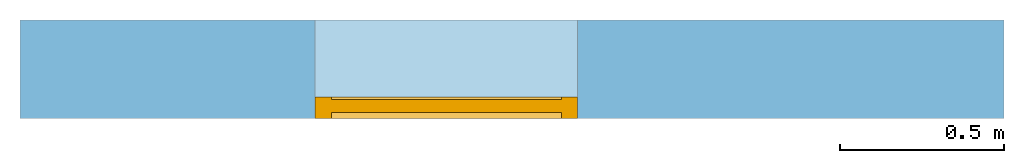
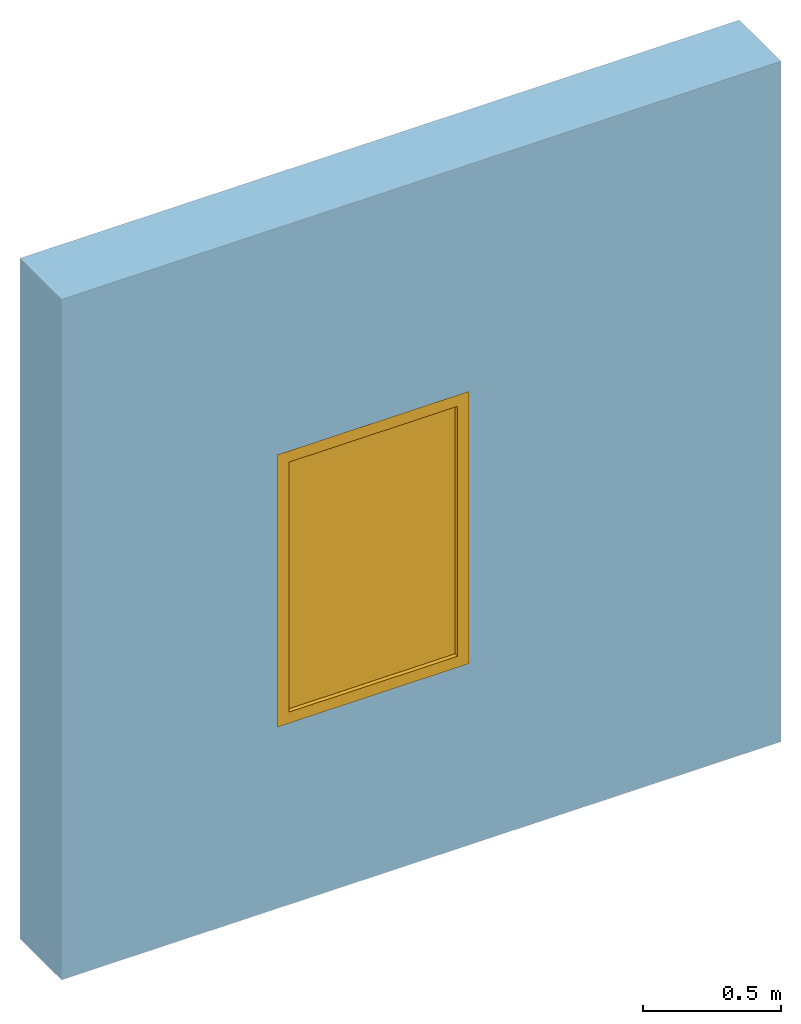
# One storey, part 2 of 2: 1 window, 1 opening, plus 1 element that does not belong to this part.
"""IFC2X3 building model written with IfcOpenShell, lengths in metres."""

from ifc_helpers import new_model, entity, si_unit, converted_unit, derived_unit, direction, frame, frame_2d, origin, place, context, subcontext, project, spatial, rectangle, extrude, faceted_brep, source, transform, mapped, material, material_list, layer, layer_set, layer_usage, type_object, type_shapes, element, fill, save


model = new_model("IFC2X3")

# Units and contexts
model_context = context("Model", 3, precision=1e-05, world=origin(), true_north=direction((6.12303176911189e-17, 1.0)))
context_of_model = context(None, 3, precision=1e-05, world=origin(), true_north=direction((6.12303176911189e-17, 1.0)))
body_context = subcontext(model_context, "Body", "Model", "MODEL_VIEW")
ifc_project = project(units=[si_unit("LENGTHUNIT", "METRE"), si_unit("AREAUNIT", "SQUARE_METRE"), si_unit("VOLUMEUNIT", "CUBIC_METRE"), converted_unit("PLANEANGLEUNIT", "DEGREE", entity("IfcRatioMeasure", 0.0174532925199433), si_unit("PLANEANGLEUNIT", "RADIAN"), dimensions=[0, 0, 0, 0, 0, 0, 0]), si_unit("MASSUNIT", "GRAM", prefix="KILO"), si_unit("TIMEUNIT", "SECOND"), si_unit("FREQUENCYUNIT", "HERTZ"), si_unit("THERMODYNAMICTEMPERATUREUNIT", "DEGREE_CELSIUS"), derived_unit("THERMALTRANSMITTANCEUNIT", [(si_unit("MASSUNIT", "GRAM", prefix="KILO"), 1), (si_unit("THERMODYNAMICTEMPERATUREUNIT", "KELVIN"), -1), (si_unit("TIMEUNIT", "SECOND"), -3)]), derived_unit("VOLUMETRICFLOWRATEUNIT", [(si_unit("LENGTHUNIT", "METRE"), 3), (si_unit("TIMEUNIT", "SECOND"), -1)]), si_unit("ELECTRICCURRENTUNIT", "AMPERE"), si_unit("ELECTRICVOLTAGEUNIT", "VOLT"), si_unit("POWERUNIT", "WATT"), si_unit("FORCEUNIT", "NEWTON", prefix="KILO"), si_unit("ILLUMINANCEUNIT", "LUX"), si_unit("LUMINOUSFLUXUNIT", "LUMEN"), si_unit("LUMINOUSINTENSITYUNIT", "CANDELA"), si_unit("PRESSUREUNIT", "PASCAL")], contexts=[model_context, context_of_model])

# Site, building, storey
site_placement = place(None, origin())
site = spatial("IfcSite", under=ifc_project, at=site_placement, CompositionType="ELEMENT")
building_placement = place(site_placement, origin())
building = spatial("IfcBuilding", under=site, at=building_placement, CompositionType="ELEMENT")
storey_placement = place(building_placement, origin())
storey = spatial("IfcBuildingStorey", under=building, at=storey_placement, Name="Nivel 1", CompositionType="ELEMENT", Elevation=0.0)

# Wall, opening, window
ifc_material_1 = material(Name="Muro por defecto")
ifc_layer = layer(ifc_material_1, 0.3)
ifc_layer_set = layer_set([ifc_layer], Name="Basic Wall:Por defecto - 30 cm")
ifc_layer_usage = layer_usage(ifc_layer_set, "AXIS2", "NEGATIVE", 0.15)
wall_type = type_object("IfcWallType", Name="Basic Wall:Por defecto - 30 cm", PredefinedType="STANDARD", material=ifc_layer_set)
wall_placement = place(storey_placement, frame((-3.7721738955546, -0.654506154817388, 0.0)))
wall = element("IfcWallStandardCase", 1, at=wall_placement, inside=storey, type_object=wall_type, material=ifc_layer_usage, Name="Basic Wall:Por defecto - 30 cm", ObjectType="Basic Wall:Por defecto - 30 cm", context=body_context, shape_type="SweptSolid", body=[
    extrude(rectangle(XDim=3.0, YDim=0.3, at=frame_2d((1.5, 0.0), x_axis=(-1.0, 0.0))), origin(), (0.0, 0.0, 1.0), 3.0),
])
opening_placement = place(wall_placement, frame((0.899999999999999, -0.150000000000003, 0.799999999999999)))
opening = element("IfcOpeningElement", 2, at=opening_placement, cuts=wall, ObjectType="Opening", context=body_context, shape_type="SweptSolid", body=[
    extrude(rectangle(XDim=1.2, YDim=0.8, at=frame_2d((0.6, 0.4), x_axis=(1.0, 0.0))), frame((0.0, 0.0, 0.0), z_axis=(0.0, 1.0, 0.0), x_axis=(0.0, 0.0, 1.0)), (0.0, 0.0, 1.0), 0.3),
])
ifc_material_2 = material(Name="Vidrio")
ifc_material_3 = material(Name="Aluminio")
ifc_material_list_1 = material_list([ifc_material_2, ifc_material_3])
ifc_material_list_2 = material_list([ifc_material_2, ifc_material_3])
window_style = type_object("IfcWindowStyle", ConstructionType="NOTDEFINED", OperationType="NOTDEFINED", ParameterTakesPrecedence=False, Sizeable=False, material=ifc_material_list_2)
shared_shape = source(origin(), body_context, "Body", "Brep", [
    faceted_brep([(0.765998931682492, 0.0572000000000026, 0.0340010683175102), (0.765998931682492, 0.0182000000000026, 0.0340010683175102), (0.0340010683175071, 0.0182000000000026, 0.0340010683175102), (0.0340010683175071, 0.0572000000000026, 0.0340010683175102), (0.765998931682492, 0.0572000000000026, 1.16599893168249), (0.765998931682492, 0.0182000000000026, 1.16599893168249), (0.0340010683175071, 0.0182000000000026, 1.16599893168249), (0.0340010683175071, 0.0572000000000026, 1.16599893168249)], [[[0, 1, 2, 3]], [[4, 5, 1, 0]], [[5, 6, 2, 1]], [[6, 7, 3, 2]], [[7, 4, 0, 3]], [[4, 7, 6, 5]]]),
    faceted_brep([(0.75099893168249, 0.0572, 1.15099893168249), (0.75099893168249, 0.0650000000000004, 1.15099893168249), (0.75099893168249, 0.0650000000000004, 0.0490010683175102), (0.75099893168249, 0.0572, 0.0490010683175103), (0.8, 0.0650000000000004, 1.2), (0.8, 0.0650000000000004, 0.0), (0.0, 0.0650000000000004, 0.0), (0.0, 0.0650000000000004, 1.2), (0.0490010683175105, 0.0650000000000004, 1.15099893168249), (0.0490010683175106, 0.0650000000000004, 0.0490010683175103), (0.0490010683175106, 0.0572, 0.0490010683175103), (0.0490010683175105, 0.0572, 1.15099893168249), (0.0340010683175107, 0.0572, 1.16599893168249), (0.0340010683175107, 0.0572, 0.0340010683175104), (0.76599893168249, 0.0572, 0.0340010683175105), (0.76599893168249, 0.0572, 1.16599893168249), (0.8, 0.0, 1.2), (0.8, 0.0, 0.0), (0.0, 0.0, 1.2), (0.0, 0.0, 0.0), (0.75099893168249, 0.0, 1.15099893168249), (0.75099893168249, 0.0, 0.0490010683175102), (0.0490010683175107, 0.0, 0.0490010683175103), (0.0490010683175105, 0.0, 1.15099893168249), (0.75099893168249, 0.0182, 1.15099893168249), (0.75099893168249, 0.0182, 0.0490010683175102), (0.0490010683175107, 0.0182, 0.0490010683175103), (0.0490010683175105, 0.0182, 1.15099893168249), (0.76599893168249, 0.0182, 1.16599893168249), (0.76599893168249, 0.0182, 0.0340010683175105), (0.0340010683175106, 0.0182, 0.0340010683175105), (0.0340010683175106, 0.0182, 1.16599893168249)], [[[0, 1, 2, 3]], [[4, 5, 6, 7], [8, 9, 2, 1]], [[3, 2, 9, 10]], [[0, 3, 10, 11], [12, 13, 14, 15]], [[4, 16, 17, 5]], [[18, 19, 17, 16], [20, 21, 22, 23]], [[5, 17, 19, 6]], [[10, 9, 8, 11]], [[6, 19, 18, 7]], [[20, 24, 25, 21]], [[21, 25, 26, 22]], [[22, 26, 27, 23]], [[28, 15, 14, 29]], [[29, 14, 13, 30]], [[27, 26, 25, 24], [28, 29, 30, 31]], [[30, 13, 12, 31]], [[11, 8, 1, 0]], [[7, 18, 16, 4]], [[31, 12, 15, 28]], [[23, 27, 24, 20]]], outer=[[True], [True, False], [True], [False, True], [True], [True, False], [True], [True], [True], [True], [True], [True], [True], [True], [False, True], [True], [True], [True], [True], [True]]),
])
type_shapes(window_style, [shared_shape])
window_placement = place(opening_placement, origin())
window = element("IfcWindow", 3, at=window_placement, inside=storey, type_object=window_style, material=ifc_material_list_1, OverallHeight=1.2, OverallWidth=0.8, context=body_context, shape_type="MappedRepresentation", body=[
    mapped(shared_shape, transform((0.0, 0.0, 0.0), scale=1.0)),
])
fill(opening, window)

save(model, "model.ifc")
